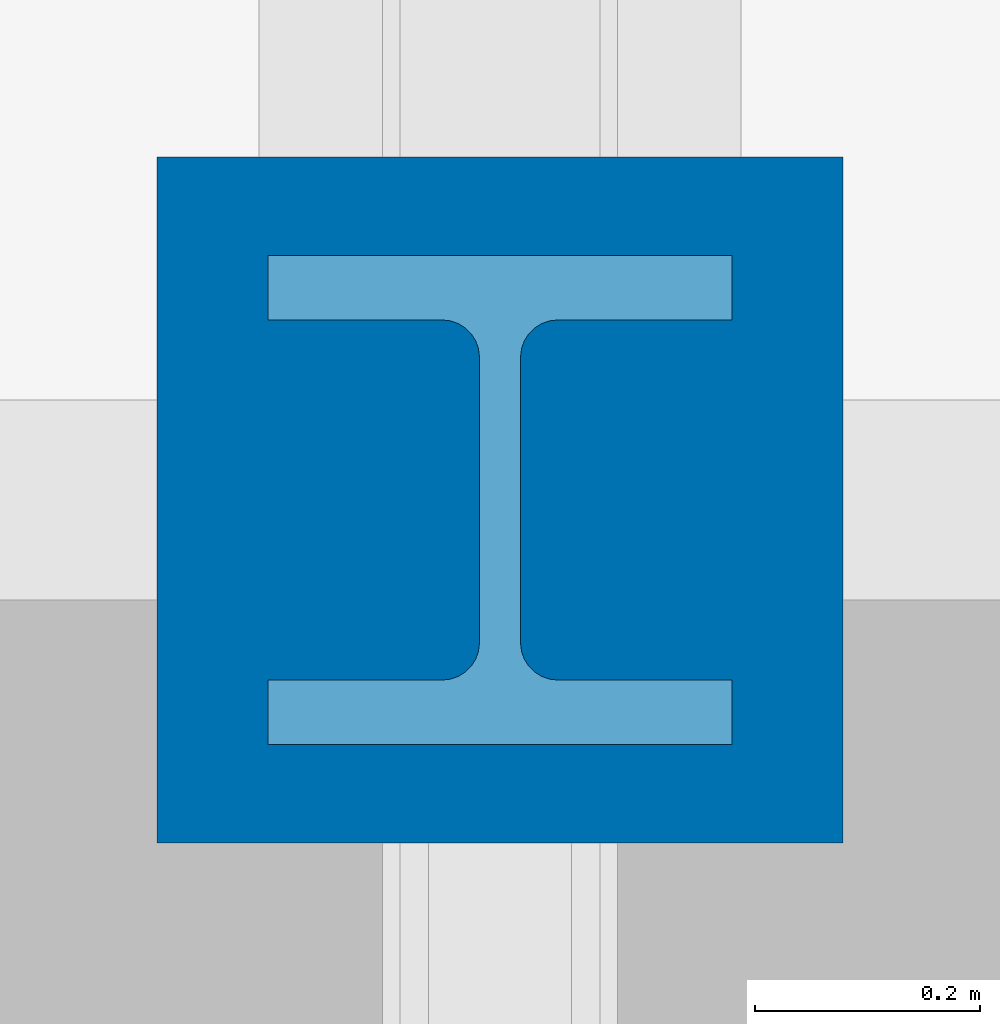
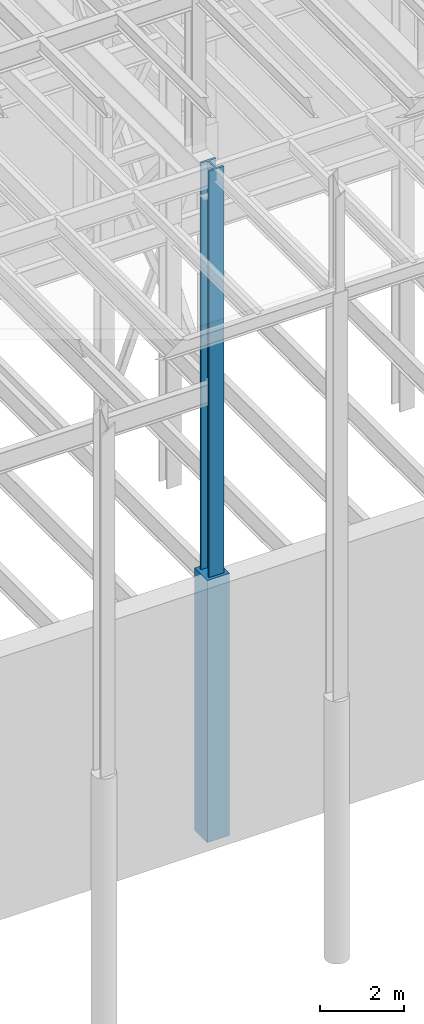
# One storey, part 33 of 150: 2 columns.
"""IFC2X3 building model written with IfcOpenShell, lengths in millimetres."""

from ifc_helpers import new_model, si_unit, frame, origin_with_axes, origin_2d_with_axis, place, context, subcontext, project, spatial, rectangle, i_section, extrude, material, type_object, element, save


model = new_model("IFC2X3")

# Units and contexts
model_context = context("Model", 3, precision=1e-05, world=origin_with_axes())
body_context = subcontext(model_context, "Body", "Model", "MODEL_VIEW")
ifc_project = project(units=[si_unit("LENGTHUNIT", "METRE", prefix="MILLI"), si_unit("AREAUNIT", "SQUARE_METRE"), si_unit("VOLUMEUNIT", "CUBIC_METRE"), si_unit("MASSUNIT", "GRAM", prefix="KILO"), si_unit("TIMEUNIT", "SECOND"), si_unit("PLANEANGLEUNIT", "RADIAN"), si_unit("SOLIDANGLEUNIT", "STERADIAN"), si_unit("THERMODYNAMICTEMPERATUREUNIT", "DEGREE_CELSIUS"), si_unit("LUMINOUSINTENSITYUNIT", "LUMEN")], contexts=[model_context])

# Site, building, storey
site_placement = place(None, origin_with_axes())
site = spatial("IfcSite", under=ifc_project, at=site_placement, CompositionType="ELEMENT")
building_placement = place(site_placement, origin_with_axes())
building = spatial("IfcBuilding", under=site, at=building_placement, Name="Undefined", CompositionType="ELEMENT")
storey_placement = place(building_placement, origin_with_axes())
storey = spatial("IfcBuildingStorey", under=building, at=storey_placement, Name="Undefined", CompositionType="ELEMENT", Elevation=0.0)

# Columns
ifc_material_1 = material(Name="STEEL/A992")
column_type_1 = type_object("IfcColumnType", Name="W14X311", PredefinedType="NOTDEFINED")
column_1_placement = place(storey_placement, frame((56591.2, 9398.0, 22707.6), z_axis=(0.0, 0.0, 1.0), x_axis=(1.0, 0.0, 0.0)))
element("IfcColumn", 1, at=column_1_placement, inside=storey, type_object=column_type_1, material=ifc_material_1, Name="COLUMN", ObjectType="W14X311", context=body_context, shape_type="SweptSolid", body=[
    extrude(i_section(OverallWidth=412.75, OverallDepth=434.975, WebThickness=36.5125, FlangeThickness=57.404, FilletRadius=33.0834, at=origin_2d_with_axis()), frame((0.0, 0.0, 12877.8), z_axis=(0.0, 0.0, -1.0), x_axis=(-1.0, 0.0, 0.0)), (0.0, 0.0, 1.0), 12877.8),
])
ifc_material_2 = material(Name="CONCRETE/5000")
column_type_2 = type_object("IfcColumnType", PredefinedType="NOTDEFINED")
column_2_placement = place(storey_placement, frame((56591.2, 9398.0, 16154.4), z_axis=(0.0, 0.0, 1.0), x_axis=(1.0, 0.0, 0.0)))
element("IfcColumn", 2, at=column_2_placement, inside=storey, type_object=column_type_2, material=ifc_material_2, Name="COLUMN", context=body_context, shape_type="SweptSolid", body=[
    extrude(rectangle(XDim=609.6, YDim=609.6, at=origin_2d_with_axis()), frame((0.0, 0.0, 7620.0), z_axis=(0.0, 0.0, -1.0), x_axis=(0.0, -1.0, 0.0)), (0.0, 0.0, 1.0), 7620.0),
])

save(model, "model.ifc")
